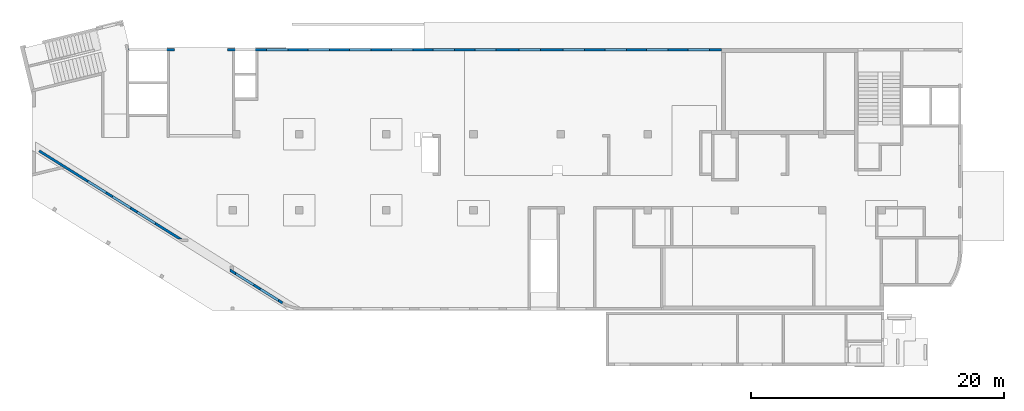
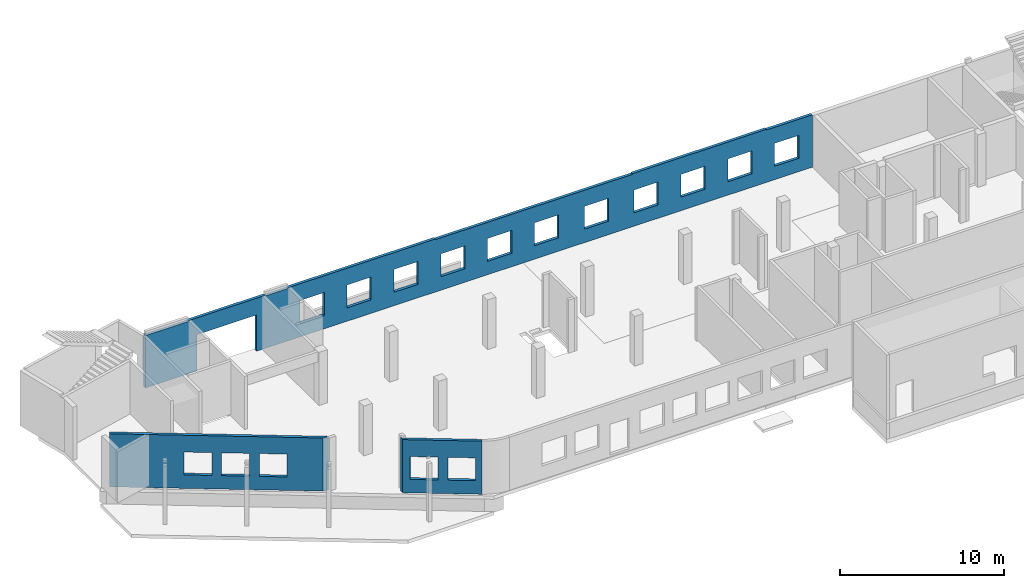
# One storey, part 6 of 8: 3 walls, 18 openings.
"""IFC4 building model written with IfcOpenShell, lengths in millimetres."""

from ifc_helpers import new_model, entity, si_unit, converted_unit, derived_unit, direction, frame, origin, place, context, subcontext, project, spatial, indexed_curve, outline, extrude, polygons, material, type_object, element, save


model = new_model("IFC4")

# Units and contexts
model_context = context("Model", 3, precision=0.01, world=origin(), true_north=direction((6.12303176911189e-17, 1.0)))
plan_context = context("Plan", 3, precision=0.01, world=origin(), true_north=direction((6.12303176911189e-17, 1.0)))
body_context = subcontext(model_context, "Body", "Model", "MODEL_VIEW")
ifc_project = project(units=[si_unit("LENGTHUNIT", "METRE", prefix="MILLI"), si_unit("AREAUNIT", "SQUARE_METRE"), si_unit("VOLUMEUNIT", "CUBIC_METRE"), converted_unit("PLANEANGLEUNIT", "DEGREE", entity("IfcRatioMeasure", 0.0174532925199433), si_unit("PLANEANGLEUNIT", "RADIAN"), dimensions=[0, 0, 0, 0, 0, 0, 0]), si_unit("MASSUNIT", "GRAM", prefix="KILO"), derived_unit("MASSDENSITYUNIT", [(si_unit("MASSUNIT", "GRAM", prefix="KILO"), 1), (si_unit("LENGTHUNIT", "METRE"), -3)]), derived_unit("MOMENTOFINERTIAUNIT", [(si_unit("LENGTHUNIT", "METRE"), 4)]), si_unit("TIMEUNIT", "SECOND"), si_unit("FREQUENCYUNIT", "HERTZ"), si_unit("THERMODYNAMICTEMPERATUREUNIT", "DEGREE_CELSIUS"), derived_unit("THERMALTRANSMITTANCEUNIT", [(si_unit("MASSUNIT", "GRAM", prefix="KILO"), 1), (si_unit("THERMODYNAMICTEMPERATUREUNIT", "KELVIN"), -1), (si_unit("TIMEUNIT", "SECOND"), -3)]), derived_unit("VOLUMETRICFLOWRATEUNIT", [(si_unit("LENGTHUNIT", "METRE"), 3), (si_unit("TIMEUNIT", "SECOND"), -1)]), derived_unit("MASSFLOWRATEUNIT", [(si_unit("MASSUNIT", "GRAM", prefix="KILO"), 1), (si_unit("TIMEUNIT", "SECOND"), -1)]), derived_unit("ROTATIONALFREQUENCYUNIT", [(si_unit("TIMEUNIT", "SECOND"), -1)]), si_unit("ELECTRICCURRENTUNIT", "AMPERE"), si_unit("ELECTRICVOLTAGEUNIT", "VOLT"), si_unit("POWERUNIT", "WATT"), si_unit("FORCEUNIT", "NEWTON", prefix="KILO"), si_unit("ILLUMINANCEUNIT", "LUX"), si_unit("LUMINOUSFLUXUNIT", "LUMEN"), si_unit("LUMINOUSINTENSITYUNIT", "CANDELA"), derived_unit("USERDEFINED", [(si_unit("MASSUNIT", "GRAM", prefix="KILO"), -1), (si_unit("LENGTHUNIT", "METRE"), -2), (si_unit("TIMEUNIT", "SECOND"), 3), (si_unit("LUMINOUSFLUXUNIT", "LUMEN"), 1)]), derived_unit("LINEARVELOCITYUNIT", [(si_unit("LENGTHUNIT", "METRE"), 1), (si_unit("TIMEUNIT", "SECOND"), -1)]), si_unit("PRESSUREUNIT", "PASCAL"), derived_unit("USERDEFINED", [(si_unit("LENGTHUNIT", "METRE"), -2), (si_unit("MASSUNIT", "GRAM", prefix="KILO"), 1), (si_unit("TIMEUNIT", "SECOND"), -2)]), derived_unit("LINEARFORCEUNIT", [(si_unit("MASSUNIT", "GRAM", prefix="KILO"), 1), (si_unit("LENGTHUNIT", "METRE"), 1), (si_unit("TIMEUNIT", "SECOND"), -2), (si_unit("LENGTHUNIT", "METRE"), -1)]), derived_unit("PLANARFORCEUNIT", [(si_unit("MASSUNIT", "GRAM", prefix="KILO"), 1), (si_unit("LENGTHUNIT", "METRE"), 1), (si_unit("TIMEUNIT", "SECOND"), -2), (si_unit("LENGTHUNIT", "METRE"), -2)])], contexts=[model_context, plan_context])

# Site, building, storey
site_placement = place(None, origin())
site = spatial("IfcSite", under=ifc_project, at=site_placement, CompositionType="ELEMENT")
building_placement = place(site_placement, origin())
building = spatial("IfcBuilding", under=site, at=building_placement, CompositionType="ELEMENT")
storey_placement = place(building_placement, origin())
storey = spatial("IfcBuildingStorey", under=building, at=storey_placement, Name="01", CompositionType="ELEMENT", Elevation=0.0)

# Wall, openings
ifc_material = material()
wall_type = type_object("IfcWallType", Name=":ADSK_ 25_200", PredefinedType="STANDARD")
wall_1_placement = place(storey_placement, frame((19848.26, 354.97, -150.0), z_axis=(0.0, 0.0, 1.0), x_axis=(-0.848052743777574, 0.529911826412026, 0.0)))
wall_1 = element("IfcWall", 1, at=wall_1_placement, inside=storey, type_object=wall_type, material=ifc_material, Name=":ADSK_ 25_200", ObjectType=":ADSK_ 25_200", PredefinedType="NOTDEFINED", context=body_context, shape_type="Tessellation", body=[
    polygons([(0.970164127863025, -100.000000000001, 0.0), (4977.58097845414, -99.9999999999989, 0.0), (4977.58097845414, -100.0, 150.0), (4977.58097845414, -100.0, 3950.0), (0.970164127862856, -100.000000000001, 3950.0), (372.19066814268, -100.000000000001, 2700.0), (2072.19066814268, -100.000000000002, 2700.0), (2072.19066814268, -100.000000000002, 1000.00000000001), (372.19066814268, -100.000000000001, 1000.00000000001), (2672.19066814269, -100.000000000002, 2700.0), (4372.19066814268, -100.000000000004, 2700.0), (4372.19066814268, -100.000000000004, 1000.00000000001), (2672.19066814269, -100.000000000002, 1000.00000000001), (-1.50586210168058e-12, 99.9999999999996, 0.0), (-1.47202250389e-12, 99.9999999999995, 3950.0), (4852.60954706614, 99.9999999999995, 3950.0), (4852.60954706614, 99.9999999999995, 0.0), (2072.19066814268, 100.000000000317, 2700.0), (372.19066814268, 100.000000000319, 2700.0), (372.19066814268, 100.000000000319, 1000.00000000001), (2072.19066814268, 100.000000000317, 1000.00000000001), (4372.19066814269, 100.000000000316, 2700.0), (2672.19066814269, 100.000000000318, 2700.0), (2672.19066814269, 100.000000000318, 1000.00000000001), (4372.19066814269, 100.000000000316, 1000.00000000001)], [[[1, 2, 3, 4, 5], [6, 7, 8, 9], [10, 11, 12, 13]], [[14, 15, 16, 17], [18, 19, 20, 21], [22, 23, 24, 25]], [[2, 1, 14, 17]], [[5, 4, 16, 15]], [[1, 5, 15, 14]], [[4, 3, 2, 17, 16]], [[19, 18, 7, 6]], [[19, 6, 9, 20]], [[20, 9, 8, 21]], [[7, 18, 21, 8]], [[23, 22, 11, 10]], [[23, 10, 13, 24]], [[24, 13, 12, 25]], [[11, 22, 25, 12]]], closed=True),
])
placement_1 = place(wall_1_placement, frame((16644.27, 10818.86, 150.0), z_axis=(0.0, 0.0, 1.0), x_axis=(-0.848052743777574, -0.529911826412026, 0.0)))
element("IfcOpeningElement", 2, at=placement_1, cuts=wall_1, Name=":ADSK_ 25_200", PredefinedType="OPENING", context=body_context, shape_type="SweptSolid", body=[
    extrude(outline(indexed_curve([(-849.999999999994, -850.0), (849.999999999994, -850.0), (849.999999999994, 849.999999999999), (-849.999999999994, 849.999999999999), (-849.999999999994, -850.0)], self_intersect=False)), frame((16914.25, 2306.23, 1700.0), z_axis=(-0.529911826412028, -0.848052743777572, 0.0), x_axis=(0.0, 0.0, -1.0)), (0.0, 0.0, 1.0), 200.000000000959),
])
element("IfcOpeningElement", 3, at=placement_1, cuts=wall_1, Name=":ADSK_ 25_200", PredefinedType="OPENING", context=body_context, shape_type="SweptSolid", body=[
    extrude(outline(indexed_curve([(-849.999999999994, -850.0), (849.999999999994, -850.0), (849.999999999994, 850.0), (-849.999999999994, 850.0), (-849.999999999994, -850.0)], self_intersect=False)), frame((18864.77, 1087.43, 1700.0), z_axis=(-0.529911826412028, -0.848052743777572, 0.0), x_axis=(0.0, 0.0, -1.0)), (0.0, 0.0, 1.0), 200.000000000962),
])

wall_2_placement = place(storey_placement, frame((7650.64, 20400.0, -150.0)))
wall_2 = element("IfcWall", 4, at=wall_2_placement, inside=storey, type_object=wall_type, material=ifc_material, Name=":ADSK_ 25_200", ObjectType=":ADSK_ 25_200", PredefinedType="NOTDEFINED", context=body_context, shape_type="Tessellation", body=[
    polygons([(48.7521159583313, -99.9999999999989, 3950.0), (48.7521159583302, -99.9999999999989, 0.0), (3049.35545648991, -99.9999999999989, 0.0), (3249.35545648991, -99.9999999999989, 0.0), (3649.35545648992, -100.000000000003, 0.0), (3649.35545648992, -100.000000000003, 2699.99999999804), (7849.35545648992, -99.9999999999989, 2699.99999999804), (7849.35545648992, -99.9999999999989, 0.0), (8249.3554564899, -99.9999999999989, 0.0), (8449.3554564899, -99.9999999999989, 0.0), (10074.3554564899, -100.000000000003, 0.0), (10274.3554564899, -100.000000000003, 0.0), (46969.3554564899, -99.9999999999989, 0.0), (46969.3554564899, -99.9999999999989, 3900.0), (43739.3554564901, -99.9999999999989, 3900.0), (43739.3554564901, -99.9999999999989, 3950.0), (40119.3554564899, -99.9999999999989, 3950.0), (39819.3554564899, -99.9999999999989, 3950.0), (34319.3554564899, -99.9999999999989, 3950.0), (34319.3554564899, -99.9999999999989, 3900.0), (33919.3554564899, -99.9999999999989, 3900.0), (33619.3554564898, -99.9999999999989, 3900.0), (26769.3554564899, -99.9999999999989, 3900.0), (26469.3554564898, -99.9999999999989, 3900.0), (20419.3554564899, -99.9999999999989, 3900.0), (20419.3554564899, -99.9999999999989, 3950.0), (20119.3554564898, -99.9999999999989, 3950.0), (13219.3554564898, -99.9999999999989, 3950.0), (12919.3554564898, -100.000000000003, 3950.0), (10274.3554564899, -100.000000000003, 3950.0), (10074.3554564899, -99.9999999999989, 3950.0), (10074.3554564899, -100.000000000003, 3900.0), (8449.35545648991, -99.9999999999989, 3900.0), (8449.35545648991, -99.9999999999989, 3950.0), (8249.3554564899, -99.9999999999989, 3950.0), (7949.35545648986, -99.9999999999989, 3950.0), (3549.35545648986, -100.000000000003, 3950.0), (3249.35545648991, -99.9999999999989, 3950.0), (3049.35545648991, -99.9999999999989, 3950.0), (3049.35545648991, -99.9999999999989, 3900.0), (49.3554564899135, -99.9999999999989, 3900.0), (49.3554564899135, -99.9999999999989, 3950.0), (27419.3554564899, -100.000000000003, 2700.0), (29119.3554564899, -99.9999999999989, 2700.0), (29119.3554564899, -99.9999999999989, 1000.00000000001), (27419.3554564899, -100.000000000003, 1000.00000000001), (41019.3554564899, -99.9999999999989, 2700.0), (42719.3554564899, -99.9999999999989, 2700.0), (42719.3554564899, -99.9999999999989, 1000.00000000001), (41019.3554564899, -99.9999999999989, 1000.00000000001), (37719.3554564899, -99.9999999999989, 2700.0), (39419.3554564899, -100.000000000003, 2700.0), (39419.3554564899, -100.000000000003, 1000.00000000001), (37719.3554564899, -99.9999999999989, 1000.00000000001), (34419.3554564899, -99.9999999999946, 2700.0), (36119.3554564899, -99.9999999999989, 2700.0), (36119.3554564899, -99.9999999999989, 1000.00000000001), (34419.3554564899, -99.9999999999946, 1000.00000000001), (30919.3554564899, -99.9999999999989, 2700.0), (32619.3554564899, -99.9999999999989, 2700.0), (32619.3554564899, -99.9999999999989, 1000.00000000001), (30919.3554564899, -99.9999999999989, 1000.00000000001), (24119.3554564899, -99.9999999999989, 2700.0), (25819.3554564899, -99.9999999999989, 2700.0), (25819.3554564899, -99.9999999999989, 1000.00000000001), (24119.3554564899, -99.9999999999989, 1000.00000000001), (20819.3554564899, -100.000000000003, 2700.0), (22519.3554564899, -99.9999999999989, 2700.0), (22519.3554564899, -99.9999999999989, 1000.00000000001), (20819.3554564899, -100.000000000003, 1000.00000000001), (17519.3554564899, -99.9999999999989, 2700.0), (19219.3554564899, -100.000000000003, 2700.0), (19219.3554564899, -100.000000000003, 1000.00000000001), (17519.3554564899, -99.9999999999989, 1000.00000000001), (14219.3554564899, -100.000000000003, 2700.0), (15919.3554564899, -99.9999999999989, 2700.0), (15919.3554564899, -99.9999999999989, 1000.00000000001), (14219.3554564899, -100.000000000003, 1000.00000000001), (10919.3554564899, -99.9999999999989, 2700.0), (12619.3554564899, -99.9999999999989, 2700.0), (12619.3554564899, -99.9999999999989, 1000.00000000001), (10919.3554564899, -99.9999999999989, 1000.00000000001), (44319.3554564899, -99.9999999999989, 2700.0), (46019.3554564899, -100.000000000003, 2700.0), (46019.3554564899, -100.000000000003, 1000.00000000001), (44319.3554564899, -99.9999999999989, 1000.00000000001), (6.86477951627945e-12, 99.9999999999989, 0.0), (-7.15290388809298e-13, 99.9999999999989, 3950.0), (49.3554564899139, 99.9999999999989, 3950.0), (49.3554564899139, 99.9999999999989, 3900.0), (3049.35545648991, 99.9999999999989, 3900.0), (3049.35545648991, 99.9999999999989, 3950.0), (8449.35545648991, 99.9999999999989, 3950.0), (8449.35545648991, 99.9999999999989, 3900.0), (10074.3554564899, 99.9999999999946, 3900.0), (10074.3554564899, 99.9999999999989, 3950.0), (20419.3554564899, 99.9999999999989, 3950.0), (20419.3554564899, 99.9999999999989, 3900.0), (34319.3554564899, 99.9999999999989, 3900.0), (34319.3554564899, 99.9999999999989, 3950.0), (43739.3554564901, 99.9999999999989, 3950.0), (43739.3554564901, 99.9999999999989, 3900.0), (46969.3554564899, 99.9999999999989, 3900.0), (46969.3554564899, 99.9999999999989, 0.0), (7849.35545648992, 99.9999999999989, 0.0), (7849.35545648992, 99.9999999999989, 2699.99999999804), (3649.35545648992, 99.9999999999946, 2699.99999999804), (3649.35545648992, 99.9999999999946, 0.0), (29119.3554564899, 100.000000000324, 2700.0), (27419.3554564899, 100.000000000319, 2700.0), (27419.3554564899, 100.000000000319, 1000.00000000001), (29119.3554564899, 100.000000000324, 1000.00000000001), (42719.3554564899, 100.000000000319, 2700.0), (41019.3554564899, 100.000000000319, 2700.0), (41019.3554564899, 100.000000000319, 1000.00000000001), (42719.3554564899, 100.000000000319, 1000.00000000001), (39419.3554564899, 100.000000000319, 2700.0), (37719.3554564899, 100.000000000319, 2700.0), (37719.3554564899, 100.000000000319, 1000.00000000001), (39419.3554564899, 100.000000000319, 1000.00000000001), (36119.3554564899, 100.000000000319, 2700.0), (34419.3554564899, 100.000000000324, 2700.0), (34419.3554564899, 100.000000000324, 1000.00000000001), (36119.3554564899, 100.000000000319, 1000.00000000001), (32619.3554564899, 100.000000000319, 2700.0), (30919.3554564899, 100.000000000319, 2700.0), (30919.3554564899, 100.000000000319, 1000.00000000001), (32619.3554564899, 100.000000000319, 1000.00000000001), (25819.3554564899, 100.000000000319, 2700.0), (24119.3554564899, 100.000000000324, 2700.0), (24119.3554564899, 100.000000000324, 1000.00000000001), (25819.3554564899, 100.000000000319, 1000.00000000001), (22519.3554564899, 100.000000000319, 2700.0), (20819.3554564899, 100.000000000319, 2700.0), (20819.3554564899, 100.000000000319, 1000.00000000001), (22519.3554564899, 100.000000000319, 1000.00000000001), (19219.3554564899, 100.000000000319, 2700.0), (17519.3554564899, 100.000000000319, 2700.0), (17519.3554564899, 100.000000000319, 1000.00000000001), (19219.3554564899, 100.000000000319, 1000.00000000001), (15919.3554564899, 100.000000000319, 2700.0), (14219.3554564899, 100.000000000315, 2700.0), (14219.3554564899, 100.000000000315, 1000.00000000001), (15919.3554564899, 100.000000000319, 1000.00000000001), (12619.3554564899, 100.000000000319, 2700.0), (10919.3554564899, 100.000000000319, 2700.0), (10919.3554564899, 100.000000000319, 1000.00000000001), (12619.3554564899, 100.000000000319, 1000.00000000001), (46019.3554564899, 100.000000000315, 2700.0), (44319.3554564899, 100.000000000319, 2700.0), (44319.3554564899, 100.000000000319, 1000.00000000001), (46019.3554564899, 100.000000000315, 1000.00000000001)], [[[1, 2, 3, 4, 5, 6, 7, 8, 9, 10, 11, 12, 13, 14, 15, 16, 17, 18, 19, 20, 21, 22, 23, 24, 25, 26, 27, 28, 29, 30, 31, 32, 33, 34, 35, 36, 37, 38, 39, 40, 41, 42], [43, 44, 45, 46], [47, 48, 49, 50], [51, 52, 53, 54], [55, 56, 57, 58], [59, 60, 61, 62], [63, 64, 65, 66], [67, 68, 69, 70], [71, 72, 73, 74], [75, 76, 77, 78], [79, 80, 81, 82], [83, 84, 85, 86]], [[87, 88, 89, 90, 91, 92, 93, 94, 95, 96, 97, 98, 99, 100, 101, 102, 103, 104, 105, 106, 107, 108], [109, 110, 111, 112], [113, 114, 115, 116], [117, 118, 119, 120], [121, 122, 123, 124], [125, 126, 127, 128], [129, 130, 131, 132], [133, 134, 135, 136], [137, 138, 139, 140], [141, 142, 143, 144], [145, 146, 147, 148], [149, 150, 151, 152]], [[2, 87, 108, 5, 4, 3]], [[2, 1, 88, 87]], [[26, 25, 98, 97]], [[100, 99, 20, 19]], [[25, 24, 23, 22, 21, 20, 99, 98]], [[33, 94, 93, 34]], [[94, 33, 32, 95]], [[95, 32, 31, 96]], [[15, 14, 103, 102]], [[15, 102, 101, 16]], [[41, 90, 89, 42]], [[90, 41, 40, 91]], [[91, 40, 39, 92]], [[1, 42, 89, 88]], [[39, 38, 37, 36, 35, 34, 93, 92]], [[31, 30, 29, 28, 27, 26, 97, 96]], [[19, 18, 17, 16, 101, 100]], [[110, 109, 44, 43]], [[110, 43, 46, 111]], [[111, 46, 45, 112]], [[44, 109, 112, 45]], [[114, 113, 48, 47]], [[114, 47, 50, 115]], [[115, 50, 49, 116]], [[48, 113, 116, 49]], [[118, 117, 52, 51]], [[118, 51, 54, 119]], [[119, 54, 53, 120]], [[52, 117, 120, 53]], [[122, 121, 56, 55]], [[122, 55, 58, 123]], [[123, 58, 57, 124]], [[56, 121, 124, 57]], [[126, 125, 60, 59]], [[126, 59, 62, 127]], [[127, 62, 61, 128]], [[60, 125, 128, 61]], [[130, 129, 64, 63]], [[130, 63, 66, 131]], [[131, 66, 65, 132]], [[64, 129, 132, 65]], [[134, 133, 68, 67]], [[134, 67, 70, 135]], [[135, 70, 69, 136]], [[68, 133, 136, 69]], [[138, 137, 72, 71]], [[138, 71, 74, 139]], [[139, 74, 73, 140]], [[72, 137, 140, 73]], [[142, 141, 76, 75]], [[142, 75, 78, 143]], [[143, 78, 77, 144]], [[76, 141, 144, 77]], [[146, 145, 80, 79]], [[146, 79, 82, 147]], [[147, 82, 81, 148]], [[80, 145, 148, 81]], [[6, 107, 106, 7]], [[7, 106, 105, 8]], [[107, 6, 5, 108]], [[14, 13, 104, 103]], [[150, 149, 84, 83]], [[150, 83, 86, 151]], [[151, 86, 85, 152]], [[84, 149, 152, 85]], [[13, 12, 11, 10, 9, 8, 105, 104]]], closed=True),
])
opening_3_placement = place(wall_2_placement, origin())
element("IfcOpeningElement", 5, at=opening_3_placement, cuts=wall_2, Name=":ADSK_ 25_200", PredefinedType="OPENING", context=body_context, shape_type="SweptSolid", body=[
    extrude(outline(indexed_curve([(-1074.99999999902, -625.000000000005), (1074.99999999902, -625.000000000005), (1074.99999999902, 624.999999999996), (-1074.99999999902, 624.999999999996), (-1074.99999999902, -625.000000000005)], self_intersect=False)), frame((62369.36, -200.0, 1825.0), z_axis=(0.0, 1.0, 0.0), x_axis=(0.0, 0.0, -1.0)), (0.0, 0.0, 1.0), 400.000000001945),
])
placement_2 = place(wall_2_placement, frame((-7650.64, -20400.0, 150.0)))
element("IfcOpeningElement", 6, at=placement_2, cuts=wall_2, Name=":ADSK_ 25_200", PredefinedType="OPENING", context=body_context, shape_type="SweptSolid", body=[
    extrude(outline(indexed_curve([(-2100.0, -1349.99999999902), (2100.0, -1349.99999999902), (2100.0, 1349.99999999902), (-2100.0, 1349.99999999902), (-2100.0, -1349.99999999902)], self_intersect=False)), frame((13400.0, 20200.0, 1200.0), z_axis=(0.0, 1.0, 0.0), x_axis=(1.0, 0.0, 0.0)), (0.0, 0.0, 1.0), 400.000000001945),
])
element("IfcOpeningElement", 7, at=placement_2, cuts=wall_2, Name=":ADSK_ 25_200", PredefinedType="OPENING", context=body_context, shape_type="SweptSolid", body=[
    extrude(outline(indexed_curve([(-849.999999999994, -850.0), (849.999999999994, -850.0), (849.999999999994, 850.000000000002), (-849.999999999994, 850.000000000002), (-849.999999999994, -850.0)], self_intersect=False)), frame((19420.0, 20300.0, 1700.0), z_axis=(0.0, 1.0, 0.0), x_axis=(0.0, 0.0, -1.0)), (0.0, 0.0, 1.0), 200.000000000959),
])
element("IfcOpeningElement", 8, at=placement_2, cuts=wall_2, Name=":ADSK_ 25_200", PredefinedType="OPENING", context=body_context, shape_type="SweptSolid", body=[
    extrude(outline(indexed_curve([(-849.999999999994, -850.000000000002), (849.999999999994, -850.000000000002), (849.999999999994, 849.999999999997), (-849.999999999994, 849.999999999997), (-849.999999999994, -850.000000000002)], self_intersect=False)), frame((22720.0, 20300.0, 1700.0), z_axis=(0.0, 1.0, 0.0), x_axis=(0.0, 0.0, -1.0)), (0.0, 0.0, 1.0), 200.000000000959),
])
element("IfcOpeningElement", 9, at=placement_2, cuts=wall_2, Name=":ADSK_ 25_200", PredefinedType="OPENING", context=body_context, shape_type="SweptSolid", body=[
    extrude(outline(indexed_curve([(-849.999999999994, -850.000000000002), (849.999999999994, -850.000000000002), (849.999999999994, 849.999999999997), (-849.999999999994, 849.999999999997), (-849.999999999994, -850.000000000002)], self_intersect=False)), frame((26020.0, 20300.0, 1700.0), z_axis=(0.0, 1.0, 0.0), x_axis=(0.0, 0.0, -1.0)), (0.0, 0.0, 1.0), 200.000000000959),
])
element("IfcOpeningElement", 10, at=placement_2, cuts=wall_2, Name=":ADSK_ 25_200", PredefinedType="OPENING", context=body_context, shape_type="SweptSolid", body=[
    extrude(outline(indexed_curve([(-849.999999999994, -850.000000000002), (849.999999999994, -850.000000000002), (849.999999999994, 849.999999999997), (-849.999999999994, 849.999999999997), (-849.999999999994, -850.000000000002)], self_intersect=False)), frame((29320.0, 20300.0, 1700.0), z_axis=(0.0, 1.0, 0.0), x_axis=(0.0, 0.0, -1.0)), (0.0, 0.0, 1.0), 200.000000000959),
])
element("IfcOpeningElement", 11, at=placement_2, cuts=wall_2, Name=":ADSK_ 25_200", PredefinedType="OPENING", context=body_context, shape_type="SweptSolid", body=[
    extrude(outline(indexed_curve([(-849.999999999994, -849.999999999997), (849.999999999994, -849.999999999997), (849.999999999994, 850.000000000002), (-849.999999999994, 850.000000000002), (-849.999999999994, -849.999999999997)], self_intersect=False)), frame((32620.0, 20300.0, 1700.0), z_axis=(0.0, 1.0, 0.0), x_axis=(0.0, 0.0, -1.0)), (0.0, 0.0, 1.0), 200.000000000959),
])
element("IfcOpeningElement", 12, at=placement_2, cuts=wall_2, Name=":ADSK_ 25_200", PredefinedType="OPENING", context=body_context, shape_type="SweptSolid", body=[
    extrude(outline(indexed_curve([(-849.999999999994, -849.999999999997), (849.999999999994, -849.999999999997), (849.999999999994, 850.000000000006), (-849.999999999994, 850.000000000006), (-849.999999999994, -849.999999999997)], self_intersect=False)), frame((39420.0, 20300.0, 1700.0), z_axis=(0.0, 1.0, 0.0), x_axis=(0.0, 0.0, -1.0)), (0.0, 0.0, 1.0), 200.000000000959),
])
element("IfcOpeningElement", 13, at=placement_2, cuts=wall_2, Name=":ADSK_ 25_200", PredefinedType="OPENING", context=body_context, shape_type="SweptSolid", body=[
    extrude(outline(indexed_curve([(-849.999999999994, -850.000000000006), (849.999999999994, -850.000000000006), (849.999999999994, 849.999999999997), (-849.999999999994, 849.999999999997), (-849.999999999994, -850.000000000006)], self_intersect=False)), frame((42920.0, 20300.0, 1700.0), z_axis=(0.0, 1.0, 0.0), x_axis=(0.0, 0.0, -1.0)), (0.0, 0.0, 1.0), 200.000000000959),
])
element("IfcOpeningElement", 14, at=placement_2, cuts=wall_2, Name=":ADSK_ 25_200", PredefinedType="OPENING", context=body_context, shape_type="SweptSolid", body=[
    extrude(outline(indexed_curve([(-849.999999999994, -850.000000000006), (849.999999999994, -850.000000000006), (849.999999999994, 849.999999999997), (-849.999999999994, 849.999999999997), (-849.999999999994, -850.000000000006)], self_intersect=False)), frame((46220.0, 20300.0, 1700.0), z_axis=(0.0, 1.0, 0.0), x_axis=(0.0, 0.0, -1.0)), (0.0, 0.0, 1.0), 200.000000000959),
])
element("IfcOpeningElement", 15, at=placement_2, cuts=wall_2, Name=":ADSK_ 25_200", PredefinedType="OPENING", context=body_context, shape_type="SweptSolid", body=[
    extrude(outline(indexed_curve([(-849.999999999994, -849.999999999997), (849.999999999994, -849.999999999997), (849.999999999994, 850.000000000006), (-849.999999999994, 850.000000000006), (-849.999999999994, -849.999999999997)], self_intersect=False)), frame((49520.0, 20300.0, 1700.0), z_axis=(0.0, 1.0, 0.0), x_axis=(0.0, 0.0, -1.0)), (0.0, 0.0, 1.0), 200.000000000959),
])
element("IfcOpeningElement", 16, at=placement_2, cuts=wall_2, Name=":ADSK_ 25_200", PredefinedType="OPENING", context=body_context, shape_type="SweptSolid", body=[
    extrude(outline(indexed_curve([(-849.999999999994, -849.999999999997), (849.999999999994, -849.999999999997), (849.999999999994, 850.000000000002), (-849.999999999994, 850.000000000002), (-849.999999999994, -849.999999999997)], self_intersect=False)), frame((35920.0, 20300.0, 1700.0), z_axis=(0.0, 1.0, 0.0), x_axis=(0.0, 0.0, -1.0)), (0.0, 0.0, 1.0), 200.000000000959),
])
element("IfcOpeningElement", 17, at=placement_2, cuts=wall_2, Name=":ADSK_ 25_200", PredefinedType="OPENING", context=body_context, shape_type="SweptSolid", body=[
    extrude(outline(indexed_curve([(-849.999999999994, -850.000000000006), (849.999999999994, -850.000000000006), (849.999999999994, 849.999999999997), (-849.999999999994, 849.999999999997), (-849.999999999994, -850.000000000006)], self_intersect=False)), frame((52820.0, 20300.0, 1700.0), z_axis=(0.0, 1.0, 0.0), x_axis=(0.0, 0.0, -1.0)), (0.0, 0.0, 1.0), 200.000000000959),
])

wall_3_placement = place(storey_placement, frame((11910.09, 5315.19, -150.0), z_axis=(0.0, 0.0, 1.0), x_axis=(-0.848052743777574, 0.529911826412026, 0.0)))
wall_3 = element("IfcWall", 18, at=wall_3_placement, inside=storey, type_object=wall_type, material=ifc_material, Name=":ADSK_ 25_200", ObjectType=":ADSK_ 25_200", PredefinedType="NOTDEFINED", context=body_context, shape_type="Tessellation", body=[
    polygons([(-1.08286712929839e-12, -99.9999999999989, 0.0), (13350.7623325176, -99.9999999999989, 0.0), (13350.7623325176, -99.9999999999989, 3950.0), (-1.62430069394759e-12, -99.9999999999978, 3950.0), (2511.71979125528, -100.000000000009, 2700.0), (4211.71979125528, -100.000000000012, 2700.0), (4211.71979125528, -100.000000000012, 1000.00000000001), (2511.71979125528, -100.000000000009, 1000.00000000001), (4811.71979125528, -100.000000000013, 2700.0), (6511.71979125528, -100.000000000015, 2700.0), (6511.71979125528, -100.000000000015, 1000.00000000001), (4811.71979125528, -100.000000000013, 1000.00000000001), (7111.71979125529, -100.000000000014, 2700.0), (8811.71979125529, -100.000000000016, 2700.0), (8811.71979125529, -100.000000000016, 1000.00000000001), (7111.71979125529, -100.000000000014, 1000.00000000001), (13350.7623325176, 100.000000000001, 0.0), (320.073152365613, 100.0, 0.0), (320.073152365612, 100.000000000001, 3950.0), (10922.962351163, 100.0, 3950.0), (11202.4176589652, 100.0, 3950.0), (13350.7623325176, 100.000000000001, 3950.0), (4211.71979125528, 100.000000000309, 2700.0), (2511.71979125528, 100.00000000031, 2700.0), (2511.71979125528, 100.00000000031, 1000.00000000001), (4211.71979125528, 100.000000000309, 1000.00000000001), (6511.71979125528, 100.000000000306, 2700.0), (4811.71979125528, 100.000000000309, 2700.0), (4811.71979125528, 100.000000000309, 1000.00000000001), (6511.71979125528, 100.000000000305, 1000.00000000001), (8811.71979125529, 100.000000000304, 2700.0), (7111.71979125529, 100.000000000304, 2700.0), (7111.71979125529, 100.000000000304, 1000.00000000001), (8811.71979125529, 100.000000000304, 1000.00000000001)], [[[1, 2, 3, 4], [5, 6, 7, 8], [9, 10, 11, 12], [13, 14, 15, 16]], [[17, 18, 19, 20, 21, 22], [23, 24, 25, 26], [27, 28, 29, 30], [31, 32, 33, 34]], [[2, 1, 18, 17]], [[3, 2, 17, 22]], [[4, 3, 22, 21, 20, 19]], [[1, 4, 19, 18]], [[24, 23, 6, 5]], [[24, 5, 8, 25]], [[25, 8, 7, 26]], [[6, 23, 26, 7]], [[28, 27, 10, 9]], [[28, 9, 12, 29]], [[29, 12, 11, 30]], [[10, 27, 30, 11]], [[32, 31, 14, 13]], [[32, 13, 16, 33]], [[33, 16, 15, 34]], [[14, 31, 34, 15]]], closed=True),
])
placement_3 = place(wall_3_placement, frame((7283.8, 10818.86, 150.0), z_axis=(0.0, 0.0, 1.0), x_axis=(-0.848052743777574, -0.529911826412026, 0.0)))
element("IfcOpeningElement", 19, at=placement_3, cuts=wall_3, Name=":ADSK_ 25_200", PredefinedType="OPENING", context=body_context, shape_type="SweptSolid", body=[
    extrude(outline(indexed_curve([(-849.999999999994, -850.0), (849.999999999994, -850.0), (849.999999999994, 850.0), (-849.999999999994, 850.0), (-849.999999999994, -850.0)], self_intersect=False)), frame((5211.12, 9619.01, 1700.0), z_axis=(-0.529911826412028, -0.848052743777572, 0.0), x_axis=(0.0, 0.0, -1.0)), (0.0, 0.0, 1.0), 200.000000000964),
])
element("IfcOpeningElement", 20, at=placement_3, cuts=wall_3, Name=":ADSK_ 25_200", PredefinedType="OPENING", context=body_context, shape_type="SweptSolid", body=[
    extrude(outline(indexed_curve([(-849.999999999994, -850.0), (849.999999999994, -850.0), (849.999999999994, 850.0), (-849.999999999994, 850.0), (-849.999999999994, -850.0)], self_intersect=False)), frame((7161.64, 8400.21, 1700.0), z_axis=(-0.529911826412028, -0.848052743777572, 0.0), x_axis=(0.0, 0.0, -1.0)), (0.0, 0.0, 1.0), 200.000000000964),
])
element("IfcOpeningElement", 21, at=placement_3, cuts=wall_3, Name=":ADSK_ 25_200", PredefinedType="OPENING", context=body_context, shape_type="SweptSolid", body=[
    extrude(outline(indexed_curve([(-849.999999999994, -850.0), (849.999999999994, -850.0), (849.999999999994, 850.0), (-849.999999999994, 850.0), (-849.999999999994, -850.0)], self_intersect=False)), frame((9112.16, 7181.41, 1700.0), z_axis=(-0.529911826412028, -0.848052743777572, 0.0), x_axis=(0.0, 0.0, -1.0)), (0.0, 0.0, 1.0), 200.000000000962),
])

save(model, "model.ifc")
